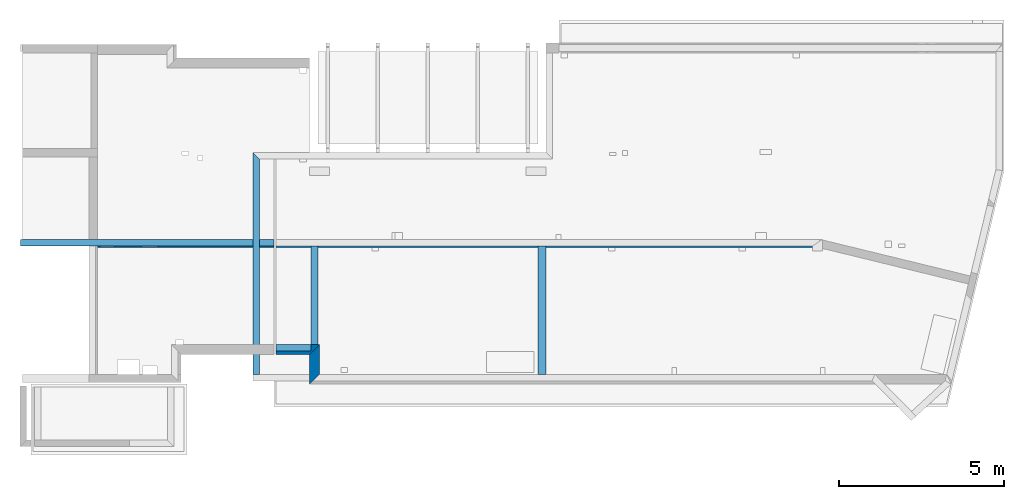
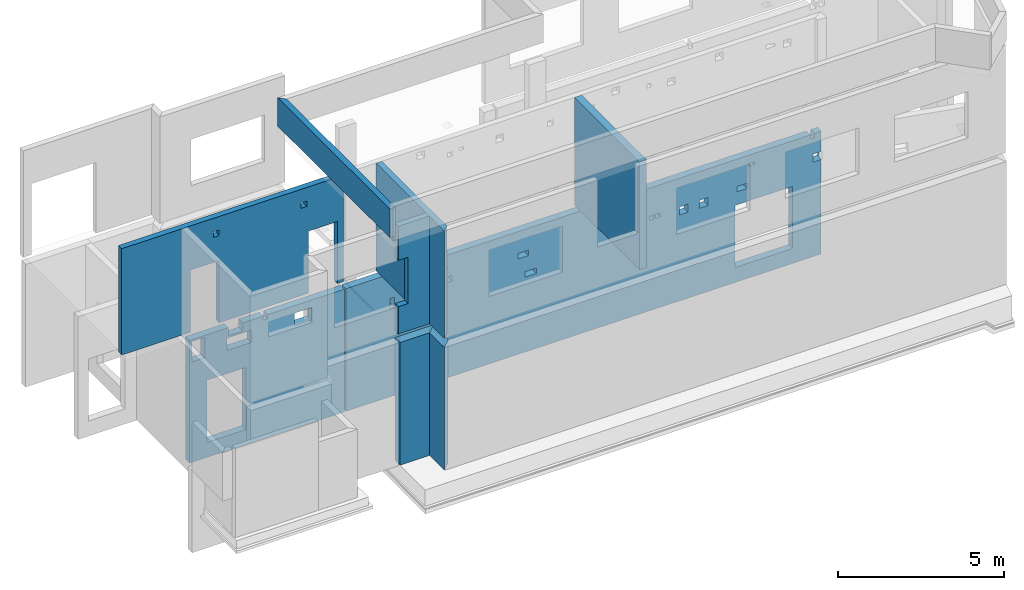
# One storey, part 2 of 7: 9 walls, 30 openings.
"""IFC2X3 building model written with IfcOpenShell, lengths in millimetres."""

from ifc_helpers import new_model, entity, si_unit, converted_unit, derived_unit, money_unit, direction, frame, frame_2d, origin_with_axes, place, context, subcontext, project, spatial, polyline, rectangle, outline, extrude, faceted_brep, material, layer, layer_set, layer_usage, type_object, element, save


model = new_model("IFC2X3")

# Units and contexts
model_context = context("Model", 3, precision=1e-05, world=origin_with_axes(), true_north=direction((0.0, 1.0)))
body_context = subcontext(model_context, "Body", "Model", "MODEL_VIEW", scale=1.0)
ifc_project = project(units=[si_unit("LENGTHUNIT", "METRE", prefix="MILLI"), si_unit("AREAUNIT", "SQUARE_METRE"), si_unit("VOLUMEUNIT", "CUBIC_METRE"), si_unit("ABSORBEDDOSEUNIT", "GRAY"), si_unit("AMOUNTOFSUBSTANCEUNIT", "MOLE"), si_unit("DOSEEQUIVALENTUNIT", "SIEVERT"), si_unit("ELECTRICCAPACITANCEUNIT", "FARAD"), si_unit("ELECTRICCHARGEUNIT", "COULOMB"), si_unit("ELECTRICCONDUCTANCEUNIT", "SIEMENS"), si_unit("ELECTRICCURRENTUNIT", "AMPERE"), si_unit("ELECTRICRESISTANCEUNIT", "OHM"), si_unit("ELECTRICVOLTAGEUNIT", "VOLT"), si_unit("ENERGYUNIT", "JOULE"), si_unit("FORCEUNIT", "NEWTON"), si_unit("FREQUENCYUNIT", "HERTZ"), si_unit("ILLUMINANCEUNIT", "LUX"), si_unit("INDUCTANCEUNIT", "HENRY"), si_unit("LUMINOUSFLUXUNIT", "LUMEN"), si_unit("LUMINOUSINTENSITYUNIT", "CANDELA"), si_unit("MAGNETICFLUXDENSITYUNIT", "TESLA"), si_unit("MAGNETICFLUXUNIT", "WEBER"), si_unit("MASSUNIT", "GRAM"), converted_unit("PLANEANGLEUNIT", "degree", entity("IfcReal", 0.0174532925199433), si_unit("PLANEANGLEUNIT", "RADIAN"), dimensions=[0, 0, 0, 0, 0, 0, 0]), si_unit("POWERUNIT", "WATT"), si_unit("PRESSUREUNIT", "PASCAL"), si_unit("RADIOACTIVITYUNIT", "BECQUEREL"), si_unit("SOLIDANGLEUNIT", "STERADIAN"), si_unit("THERMODYNAMICTEMPERATUREUNIT", "KELVIN"), si_unit("TIMEUNIT", "SECOND"), derived_unit("ACCELERATIONUNIT", [(si_unit("LENGTHUNIT", "METRE", prefix="MILLI"), 1), (si_unit("TIMEUNIT", "SECOND"), -2)]), derived_unit("ANGULARVELOCITYUNIT", [(converted_unit("PLANEANGLEUNIT", "degree", entity("IfcReal", 0.0174532925199433), si_unit("PLANEANGLEUNIT", "RADIAN"), dimensions=[0, 0, 0, 0, 0, 0, 0]), 1), (si_unit("TIMEUNIT", "SECOND"), -1)]), derived_unit("CURVATUREUNIT", [(converted_unit("PLANEANGLEUNIT", "degree", entity("IfcReal", 0.0174532925199433), si_unit("PLANEANGLEUNIT", "RADIAN"), dimensions=[0, 0, 0, 0, 0, 0, 0]), 1), (si_unit("LENGTHUNIT", "METRE", prefix="MILLI"), -1)]), derived_unit("DYNAMICVISCOSITYUNIT", [(si_unit("PRESSUREUNIT", "PASCAL"), 1), (si_unit("TIMEUNIT", "SECOND"), 1)]), derived_unit("HEATFLUXDENSITYUNIT", [(si_unit("POWERUNIT", "WATT"), 1), (si_unit("LENGTHUNIT", "METRE", prefix="MILLI"), -2)]), derived_unit("HEATINGVALUEUNIT", [(si_unit("ENERGYUNIT", "JOULE"), 1), (si_unit("MASSUNIT", "GRAM"), -1)]), derived_unit("INTEGERCOUNTRATEUNIT", [(si_unit("TIMEUNIT", "SECOND"), -1)]), derived_unit("IONCONCENTRATIONUNIT", [(si_unit("MASSUNIT", "GRAM"), 1), (si_unit("VOLUMEUNIT", "CUBIC_METRE"), -1)]), derived_unit("ISOTHERMALMOISTURECAPACITYUNIT", [(si_unit("VOLUMEUNIT", "CUBIC_METRE"), 1), (si_unit("MASSUNIT", "GRAM"), -1)]), derived_unit("KINEMATICVISCOSITYUNIT", [(si_unit("AREAUNIT", "SQUARE_METRE"), 1), (si_unit("TIMEUNIT", "SECOND"), -1)]), derived_unit("LINEARFORCEUNIT", [(si_unit("FORCEUNIT", "NEWTON"), 1), (si_unit("LENGTHUNIT", "METRE", prefix="MILLI"), -1)]), derived_unit("LINEARMOMENTUNIT", [(si_unit("FORCEUNIT", "NEWTON"), 1), (si_unit("LENGTHUNIT", "METRE", prefix="MILLI"), -1)]), derived_unit("LINEARSTIFFNESSUNIT", [(si_unit("FORCEUNIT", "NEWTON"), 1), (si_unit("LENGTHUNIT", "METRE", prefix="MILLI"), -1)]), derived_unit("LINEARVELOCITYUNIT", [(si_unit("LENGTHUNIT", "METRE", prefix="MILLI"), 1), (si_unit("TIMEUNIT", "SECOND"), -1)]), derived_unit("LUMINOUSINTENSITYDISTRIBUTIONUNIT", [(si_unit("LUMINOUSINTENSITYUNIT", "CANDELA"), 1), (si_unit("LUMINOUSFLUXUNIT", "LUMEN"), -1)]), derived_unit("MASSDENSITYUNIT", [(si_unit("MASSUNIT", "GRAM"), 1), (si_unit("VOLUMEUNIT", "CUBIC_METRE"), -1)]), derived_unit("MASSFLOWRATEUNIT", [(si_unit("MASSUNIT", "GRAM"), 1), (si_unit("TIMEUNIT", "SECOND"), -1)]), derived_unit("MASSPERLENGTHUNIT", [(si_unit("MASSUNIT", "GRAM"), 1), (si_unit("LENGTHUNIT", "METRE", prefix="MILLI"), -1)]), derived_unit("MODULUSOFELASTICITYUNIT", [(si_unit("FORCEUNIT", "NEWTON"), 1), (si_unit("AREAUNIT", "SQUARE_METRE"), -1)]), derived_unit("MODULUSOFLINEARSUBGRADEREACTIONUNIT", [(si_unit("FORCEUNIT", "NEWTON"), 1), (si_unit("LENGTHUNIT", "METRE", prefix="MILLI"), -2)]), derived_unit("MODULUSOFROTATIONALSUBGRADEREACTIONUNIT", [(si_unit("FORCEUNIT", "NEWTON"), 1), (si_unit("LENGTHUNIT", "METRE", prefix="MILLI"), 1)]), derived_unit("MODULUSOFSUBGRADEREACTIONUNIT", [(si_unit("FORCEUNIT", "NEWTON"), 1), (si_unit("VOLUMEUNIT", "CUBIC_METRE"), -1)]), derived_unit("MOISTUREDIFFUSIVITYUNIT", [(si_unit("VOLUMEUNIT", "CUBIC_METRE"), 1), (si_unit("TIMEUNIT", "SECOND"), -1)]), derived_unit("MOLECULARWEIGHTUNIT", [(si_unit("MASSUNIT", "GRAM"), 1), (si_unit("AMOUNTOFSUBSTANCEUNIT", "MOLE"), -1)]), derived_unit("PLANARFORCEUNIT", [(si_unit("FORCEUNIT", "NEWTON"), 1), (si_unit("LENGTHUNIT", "METRE", prefix="MILLI"), -2)]), derived_unit("ROTATIONALFREQUENCYUNIT", [(si_unit("TIMEUNIT", "SECOND"), -1)]), derived_unit("ROTATIONALMASSUNIT", [(si_unit("MASSUNIT", "GRAM"), 1), (si_unit("LENGTHUNIT", "METRE", prefix="MILLI"), 2)]), derived_unit("ROTATIONALSTIFFNESSUNIT", [(si_unit("FORCEUNIT", "NEWTON"), 1), (si_unit("LENGTHUNIT", "METRE", prefix="MILLI"), 1), (converted_unit("PLANEANGLEUNIT", "degree", entity("IfcReal", 0.0174532925199433), si_unit("PLANEANGLEUNIT", "RADIAN"), dimensions=[0, 0, 0, 0, 0, 0, 0]), -1)]), derived_unit("SECTIONAREAINTEGRALUNIT", [(si_unit("LENGTHUNIT", "METRE", prefix="MILLI"), 5)]), derived_unit("SECTIONMODULUSUNIT", [(si_unit("LENGTHUNIT", "METRE", prefix="MILLI"), 3)]), derived_unit("SHEARMODULUSUNIT", [(si_unit("FORCEUNIT", "NEWTON"), 1), (si_unit("AREAUNIT", "SQUARE_METRE"), -1)]), derived_unit("SOUNDPOWERUNIT", [(si_unit("ENERGYUNIT", "JOULE"), 1), (si_unit("TIMEUNIT", "SECOND"), -1)]), derived_unit("SPECIFICHEATCAPACITYUNIT", [(si_unit("FORCEUNIT", "NEWTON"), 1), (si_unit("MASSUNIT", "GRAM"), -1), (si_unit("THERMODYNAMICTEMPERATUREUNIT", "KELVIN"), -1)]), derived_unit("TEMPERATUREGRADIENTUNIT", [(si_unit("THERMODYNAMICTEMPERATUREUNIT", "KELVIN"), 1), (si_unit("LENGTHUNIT", "METRE", prefix="MILLI"), -1)]), derived_unit("THERMALADMITTANCEUNIT", [(si_unit("POWERUNIT", "WATT"), 1), (si_unit("AREAUNIT", "SQUARE_METRE"), -1), (si_unit("THERMODYNAMICTEMPERATUREUNIT", "KELVIN"), -1)]), derived_unit("THERMALCONDUCTANCEUNIT", [(si_unit("POWERUNIT", "WATT"), 1), (si_unit("LENGTHUNIT", "METRE", prefix="MILLI"), -1), (si_unit("THERMODYNAMICTEMPERATUREUNIT", "KELVIN"), -1)]), derived_unit("THERMALEXPANSIONCOEFFICIENTUNIT", [(si_unit("THERMODYNAMICTEMPERATUREUNIT", "KELVIN"), -1)]), derived_unit("THERMALRESISTANCEUNIT", [(si_unit("AREAUNIT", "SQUARE_METRE"), 1), (si_unit("POWERUNIT", "WATT"), -1)]), derived_unit("THERMALTRANSMITTANCEUNIT", [(si_unit("POWERUNIT", "WATT"), 1), (si_unit("AREAUNIT", "SQUARE_METRE"), -1), (si_unit("THERMODYNAMICTEMPERATUREUNIT", "KELVIN"), -1)]), derived_unit("TORQUEUNIT", [(si_unit("FORCEUNIT", "NEWTON"), 1), (si_unit("LENGTHUNIT", "METRE", prefix="MILLI"), 1)]), derived_unit("VAPORPERMEABILITYUNIT", [(si_unit("MASSUNIT", "GRAM"), 1), (si_unit("TIMEUNIT", "SECOND"), -1)]), derived_unit("VOLUMETRICFLOWRATEUNIT", [(si_unit("VOLUMEUNIT", "CUBIC_METRE"), 1), (si_unit("TIMEUNIT", "SECOND"), -1)]), derived_unit("WARPINGCONSTANTUNIT", [(si_unit("LENGTHUNIT", "METRE", prefix="MILLI"), 6)]), derived_unit("WARPINGMOMENTUNIT", [(si_unit("FORCEUNIT", "NEWTON"), 1), (si_unit("LENGTHUNIT", "METRE", prefix="MILLI"), 2)]), money_unit("USD")], contexts=[model_context])

# Site, building, storey
site_placement = place(None, origin_with_axes())
site = spatial("IfcSite", under=ifc_project, at=site_placement, CompositionType="ELEMENT")
building_placement = place(site_placement, origin_with_axes())
building = spatial("IfcBuilding", under=site, at=building_placement, Name="1", CompositionType="ELEMENT")
storey_placement = place(building_placement, frame((0.0, 0.0, -4900.0), z_axis=(0.0, 0.0, 1.0), x_axis=(1.0, 0.0, 0.0)))
storey = spatial("IfcBuildingStorey", under=building, at=storey_placement, Name="-2", CompositionType="ELEMENT", Elevation=-4900.0)

# Wall, openings
ifc_material = material()
ifc_layer_1 = layer(ifc_material, 250.0, ventilated=False)
ifc_layer_set_1 = layer_set([ifc_layer_1])
ifc_layer_usage_1 = layer_usage(ifc_layer_set_1, "AXIS2", "POSITIVE", 0.0)
wall_type = type_object("IfcWallType", PredefinedType="NOTDEFINED")
wall_1_placement = place(storey_placement, frame((2530.0, 3850.0, 0.0), z_axis=(0.0, 0.0, 1.0), x_axis=(1.0, 0.0, 0.0)))
wall_1 = element("IfcWallStandardCase", 1, at=wall_1_placement, inside=storey, type_object=wall_type, material=ifc_layer_usage_1, context=body_context, shape_type="SweptSolid", body=[
    extrude(rectangle(XDim=5370.0, YDim=250.0, at=frame_2d((2685.0, 125.0), x_axis=(1.0, 0.0))), origin_with_axes(), (0.0, 0.0, 1.0), 4500.0),
])
opening_1_placement = place(wall_1_placement, frame((600.0, 0.0, 550.0), z_axis=(0.0, 0.0, 1.0), x_axis=(1.0, 0.0, 0.0)))
element("IfcOpeningElement", 2, at=opening_1_placement, cuts=wall_1, ObjectType="Opening", context=body_context, shape_type="SweptSolid", body=[
    extrude(rectangle(XDim=2280.0, YDim=1350.0, at=frame_2d((-675.0, 1140.0), x_axis=(0.0, -1.0))), frame((0.0, 0.0, 0.0), z_axis=(0.0, 1.0, 0.0), x_axis=(-1.0, 0.0, 0.0)), (0.0, 0.0, 1.0), 250.0),
])
opening_2_placement = place(wall_1_placement, frame((75.0, 0.0, 3680.0), z_axis=(0.0, 0.0, 1.0), x_axis=(1.0, 0.0, 0.0)))
element("IfcOpeningElement", 3, at=opening_2_placement, cuts=wall_1, ObjectType="Opening", context=body_context, shape_type="SweptSolid", body=[
    extrude(rectangle(XDim=750.0, YDim=450.0, at=frame_2d((-225.0, 375.0), x_axis=(0.0, -1.0))), frame((0.0, 0.0, 0.0), z_axis=(0.0, 1.0, 0.0), x_axis=(-1.0, 0.0, 0.0)), (0.0, 0.0, 1.0), 250.0),
])
opening_3_placement = place(wall_1_placement, frame((1290.0, 0.0, 3680.0), z_axis=(0.0, 0.0, 1.0), x_axis=(1.0, 0.0, 0.0)))
element("IfcOpeningElement", 4, at=opening_3_placement, cuts=wall_1, ObjectType="Opening", context=body_context, shape_type="SweptSolid", body=[
    extrude(rectangle(XDim=450.0, YDim=850.0, at=frame_2d((-425.0, 225.0), x_axis=(0.0, -1.0))), frame((0.0, 0.0, 0.0), z_axis=(0.0, 1.0, 0.0), x_axis=(-1.0, 0.0, 0.0)), (0.0, 0.0, 1.0), 250.0),
])
opening_4_placement = place(wall_1_placement, frame((1340.0, 0.0, 4200.0), z_axis=(0.0, 0.0, 1.0), x_axis=(1.0, 0.0, 0.0)))
element("IfcOpeningElement", 5, at=opening_4_placement, cuts=wall_1, ObjectType="Opening", context=body_context, shape_type="SweptSolid", body=[
    extrude(rectangle(XDim=300.0, YDim=500.0, at=frame_2d((-250.0, 150.0), x_axis=(0.0, -1.0))), frame((0.0, 0.0, 0.0), z_axis=(0.0, 1.0, 0.0), x_axis=(-1.0, 0.0, 0.0)), (0.0, 0.0, 1.0), 250.0),
])
opening_5_placement = place(wall_1_placement, frame((2550.0, 0.0, 4350.0), z_axis=(0.0, 0.0, 1.0), x_axis=(1.0, 0.0, 0.0)))
element("IfcOpeningElement", 6, at=opening_5_placement, cuts=wall_1, ObjectType="Opening", context=body_context, shape_type="SweptSolid", body=[
    extrude(rectangle(XDim=150.0, YDim=150.0, at=frame_2d((-75.0, 75.0), x_axis=(0.0, -1.0))), frame((0.0, 0.0, 0.0), z_axis=(0.0, 1.0, 0.0), x_axis=(-1.0, 0.0, 0.0)), (0.0, 0.0, 1.0), 250.0),
])
opening_6_placement = place(wall_1_placement, frame((3630.0, 0.0, 3780.0), z_axis=(0.0, 0.0, 1.0), x_axis=(1.0, 0.0, 0.0)))
element("IfcOpeningElement", 7, at=opening_6_placement, cuts=wall_1, ObjectType="Opening", context=body_context, shape_type="SweptSolid", body=[
    extrude(rectangle(XDim=450.0, YDim=600.0, at=frame_2d((-300.0, 225.0), x_axis=(0.0, -1.0))), frame((0.0, 0.0, 0.0), z_axis=(0.0, 1.0, 0.0), x_axis=(-1.0, 0.0, 0.0)), (0.0, 0.0, 1.0), 250.0),
])

wall_2_placement = place(storey_placement, frame((7950.0, 3850.0, 0.0), z_axis=(0.0, 0.0, 1.0), x_axis=(1.0, 0.0, 0.0)))
wall_2 = element("IfcWallStandardCase", 8, at=wall_2_placement, inside=storey, type_object=wall_type, material=ifc_layer_usage_1, context=body_context, shape_type="SweptSolid", body=[
    extrude(outline(polyline([(16515.0, 250.0), (0.0, 250.0), (0.0, 0.0), (16484.99, 0.0), (16515.0, 250.0)])), origin_with_axes(), (0.0, 0.0, 1.0), 4500.0),
])
opening_7_placement = place(wall_2_placement, frame((13495.0, 0.0, 550.0), z_axis=(0.0, 0.0, 1.0), x_axis=(1.0, 0.0, 0.0)))
element("IfcOpeningElement", 9, at=opening_7_placement, cuts=wall_2, ObjectType="Opening", context=body_context, shape_type="SweptSolid", body=[
    extrude(rectangle(XDim=2280.0, YDim=2000.0, at=frame_2d((-1000.0, 1140.0), x_axis=(0.0, -1.0))), frame((0.0, 0.0, 0.0), z_axis=(0.0, 1.0, 0.0), x_axis=(-1.0, 0.0, 0.0)), (0.0, 0.0, 1.0), 250.0),
])
opening_8_placement = place(wall_2_placement, frame((1525.0, 0.0, 3240.0), z_axis=(0.0, 0.0, 1.0), x_axis=(1.0, 0.0, 0.0)))
element("IfcOpeningElement", 10, at=opening_8_placement, cuts=wall_2, ObjectType="Opening", context=body_context, shape_type="SweptSolid", body=[
    extrude(rectangle(XDim=360.0, YDim=150.0, at=frame_2d((-75.0, 180.0), x_axis=(0.0, -1.0))), frame((0.0, 0.0, 0.0), z_axis=(0.0, 1.0, 0.0), x_axis=(-1.0, 0.0, 0.0)), (0.0, 0.0, 1.0), 250.0),
])
opening_9_placement = place(wall_2_placement, frame((3025.0, 0.0, 3500.0), z_axis=(0.0, 0.0, 1.0), x_axis=(1.0, 0.0, 0.0)))
element("IfcOpeningElement", 11, at=opening_9_placement, cuts=wall_2, ObjectType="Opening", context=body_context, shape_type="SweptSolid", body=[
    extrude(rectangle(XDim=200.0, YDim=200.0, at=frame_2d((-100.0, 100.0), x_axis=(0.0, -1.0))), frame((0.0, 0.0, 0.0), z_axis=(0.0, 1.0, 0.0), x_axis=(-1.0, 0.0, 0.0)), (0.0, 0.0, 1.0), 250.0),
])
opening_10_placement = place(wall_2_placement, frame((3475.0, 0.0, 3500.0), z_axis=(0.0, 0.0, 1.0), x_axis=(1.0, 0.0, 0.0)))
element("IfcOpeningElement", 12, at=opening_10_placement, cuts=wall_2, ObjectType="Opening", context=body_context, shape_type="SweptSolid", body=[
    extrude(rectangle(XDim=200.0, YDim=200.0, at=frame_2d((-100.0, 100.0), x_axis=(0.0, -1.0))), frame((0.0, 0.0, 0.0), z_axis=(0.0, 1.0, 0.0), x_axis=(-1.0, 0.0, 0.0)), (0.0, 0.0, 1.0), 250.0),
])
opening_11_placement = place(wall_2_placement, frame((5975.0, 0.0, 3500.0), z_axis=(0.0, 0.0, 1.0), x_axis=(1.0, 0.0, 0.0)))
element("IfcOpeningElement", 13, at=opening_11_placement, cuts=wall_2, ObjectType="Opening", context=body_context, shape_type="SweptSolid", body=[
    extrude(rectangle(XDim=200.0, YDim=350.0, at=frame_2d((-175.0, 100.0), x_axis=(0.0, -1.0))), frame((0.0, 0.0, 0.0), z_axis=(0.0, 1.0, 0.0), x_axis=(-1.0, 0.0, 0.0)), (0.0, 0.0, 1.0), 250.0),
])
opening_12_placement = place(wall_2_placement, frame((3315.0, 0.0, 4000.0), z_axis=(0.0, 0.0, 1.0), x_axis=(1.0, 0.0, 0.0)))
element("IfcOpeningElement", 14, at=opening_12_placement, cuts=wall_2, ObjectType="Opening", context=body_context, shape_type="SweptSolid", body=[
    extrude(rectangle(XDim=100.0, YDim=200.0, at=frame_2d((-100.0, 50.0), x_axis=(0.0, -1.0))), frame((0.0, 0.0, 0.0), z_axis=(0.0, 1.0, 0.0), x_axis=(-1.0, 0.0, 0.0)), (0.0, 0.0, 1.0), 250.0),
])
opening_13_placement = place(wall_2_placement, frame((6205.0, 0.0, 2750.0), z_axis=(0.0, 0.0, 1.0), x_axis=(1.0, 0.0, 0.0)))
element("IfcOpeningElement", 15, at=opening_13_placement, cuts=wall_2, ObjectType="Opening", context=body_context, shape_type="SweptSolid", body=[
    extrude(rectangle(XDim=200.0, YDim=400.0, at=frame_2d((-200.0, 100.0), x_axis=(0.0, -1.0))), frame((0.0, 0.0, 0.0), z_axis=(0.0, 1.0, 0.0), x_axis=(-1.0, 0.0, 0.0)), (0.0, 0.0, 1.0), 250.0),
])
opening_14_placement = place(wall_2_placement, frame((9635.0, 0.0, 3300.0), z_axis=(0.0, 0.0, 1.0), x_axis=(1.0, 0.0, 0.0)))
element("IfcOpeningElement", 16, at=opening_14_placement, cuts=wall_2, ObjectType="Opening", context=body_context, shape_type="SweptSolid", body=[
    extrude(rectangle(XDim=200.0, YDim=200.0, at=frame_2d((-100.0, 100.0), x_axis=(0.0, -1.0))), frame((0.0, 0.0, 0.0), z_axis=(0.0, 1.0, 0.0), x_axis=(-1.0, 0.0, 0.0)), (0.0, 0.0, 1.0), 250.0),
])
opening_15_placement = place(wall_2_placement, frame((9985.0, 0.0, 3300.0), z_axis=(0.0, 0.0, 1.0), x_axis=(1.0, 0.0, 0.0)))
element("IfcOpeningElement", 17, at=opening_15_placement, cuts=wall_2, ObjectType="Opening", context=body_context, shape_type="SweptSolid", body=[
    extrude(rectangle(XDim=200.0, YDim=200.0, at=frame_2d((-100.0, 100.0), x_axis=(0.0, -1.0))), frame((0.0, 0.0, 0.0), z_axis=(0.0, 1.0, 0.0), x_axis=(-1.0, 0.0, 0.0)), (0.0, 0.0, 1.0), 250.0),
])
opening_16_placement = place(wall_2_placement, frame((10535.0, 0.0, 3325.0), z_axis=(0.0, 0.0, 1.0), x_axis=(1.0, 0.0, 0.0)))
element("IfcOpeningElement", 18, at=opening_16_placement, cuts=wall_2, ObjectType="Opening", context=body_context, shape_type="SweptSolid", body=[
    extrude(rectangle(XDim=150.0, YDim=150.0, at=frame_2d((-75.0, 75.0), x_axis=(0.0, -1.0))), frame((0.0, 0.0, 0.0), z_axis=(0.0, 1.0, 0.0), x_axis=(-1.0, 0.0, 0.0)), (0.0, 0.0, 1.0), 250.0),
])
opening_17_placement = place(wall_2_placement, frame((10745.0, 0.0, 3325.0), z_axis=(0.0, 0.0, 1.0), x_axis=(1.0, 0.0, 0.0)))
element("IfcOpeningElement", 19, at=opening_17_placement, cuts=wall_2, ObjectType="Opening", context=body_context, shape_type="SweptSolid", body=[
    extrude(rectangle(XDim=150.0, YDim=150.0, at=frame_2d((-75.0, 75.0), x_axis=(0.0, -1.0))), frame((0.0, 0.0, 0.0), z_axis=(0.0, 1.0, 0.0), x_axis=(-1.0, 0.0, 0.0)), (0.0, 0.0, 1.0), 250.0),
])
opening_18_placement = place(wall_2_placement, frame((11565.0, 0.0, 3150.0), z_axis=(0.0, 0.0, 1.0), x_axis=(1.0, 0.0, 0.0)))
element("IfcOpeningElement", 20, at=opening_18_placement, cuts=wall_2, ObjectType="Opening", context=body_context, shape_type="SweptSolid", body=[
    extrude(rectangle(XDim=300.0, YDim=300.0, at=frame_2d((-150.0, 150.0), x_axis=(0.0, -1.0))), frame((0.0, 0.0, 0.0), z_axis=(0.0, 1.0, 0.0), x_axis=(-1.0, 0.0, 0.0)), (0.0, 0.0, 1.0), 250.0),
])
opening_19_placement = place(wall_2_placement, frame((12265.0, 0.0, 3150.0), z_axis=(0.0, 0.0, 1.0), x_axis=(1.0, 0.0, 0.0)))
element("IfcOpeningElement", 21, at=opening_19_placement, cuts=wall_2, ObjectType="Opening", context=body_context, shape_type="SweptSolid", body=[
    extrude(rectangle(XDim=300.0, YDim=300.0, at=frame_2d((-150.0, 150.0), x_axis=(0.0, -1.0))), frame((0.0, 0.0, 0.0), z_axis=(0.0, 1.0, 0.0), x_axis=(-1.0, 0.0, 0.0)), (0.0, 0.0, 1.0), 250.0),
])
opening_20_placement = place(wall_2_placement, frame((13565.0, 0.0, 3300.0), z_axis=(0.0, 0.0, 1.0), x_axis=(1.0, 0.0, 0.0)))
element("IfcOpeningElement", 22, at=opening_20_placement, cuts=wall_2, ObjectType="Opening", context=body_context, shape_type="SweptSolid", body=[
    extrude(rectangle(XDim=200.0, YDim=350.0, at=frame_2d((-175.0, 100.0), x_axis=(0.0, -1.0))), frame((0.0, 0.0, 0.0), z_axis=(0.0, 1.0, 0.0), x_axis=(-1.0, 0.0, 0.0)), (0.0, 0.0, 1.0), 250.0),
])
opening_21_placement = place(wall_2_placement, frame((16205.0, 0.0, 3465.0), z_axis=(0.0, 0.0, 1.0), x_axis=(1.0, 0.0, 0.0)))
element("IfcOpeningElement", 23, at=opening_21_placement, cuts=wall_2, ObjectType="Opening", context=body_context, shape_type="SweptSolid", body=[
    extrude(rectangle(XDim=300.0, YDim=300.0, at=frame_2d((-150.0, 150.0), x_axis=(0.0, -1.0))), frame((0.0, 0.0, 0.0), z_axis=(0.0, 1.0, 0.0), x_axis=(-1.0, 0.0, 0.0)), (0.0, 0.0, 1.0), 250.0),
])
opening_22_placement = place(wall_2_placement, frame((9549.96, 0.0, 2950.0), z_axis=(0.0, 0.0, 1.0), x_axis=(1.0, 0.0, 0.0)))
element("IfcOpeningElement", 24, at=opening_22_placement, cuts=wall_2, ObjectType="Opening", context=body_context, shape_type="SweptSolid", body=[
    extrude(rectangle(XDim=200.0, YDim=400.0, at=frame_2d((-200.0, 100.0), x_axis=(0.0, -1.0))), frame((0.0, 0.0, 0.0), z_axis=(0.0, 1.0, 0.0), x_axis=(-1.0, 0.0, 0.0)), (0.0, 0.0, 1.0), 250.0),
])
opening_23_placement = place(wall_2_placement, frame((10079.96, 0.0, 4100.0), z_axis=(0.0, 0.0, 1.0), x_axis=(1.0, 0.0, 0.0)))
element("IfcOpeningElement", 25, at=opening_23_placement, cuts=wall_2, ObjectType="Opening", context=body_context, shape_type="SweptSolid", body=[
    extrude(rectangle(XDim=100.0, YDim=200.0, at=frame_2d((-100.0, 50.0), x_axis=(0.0, -1.0))), frame((0.0, 0.0, 0.0), z_axis=(0.0, 1.0, 0.0), x_axis=(-1.0, 0.0, 0.0)), (0.0, 0.0, 1.0), 250.0),
])
opening_24_placement = place(wall_2_placement, frame((13965.0, 0.0, 4100.0), z_axis=(0.0, 0.0, 1.0), x_axis=(1.0, 0.0, 0.0)))
element("IfcOpeningElement", 26, at=opening_24_placement, cuts=wall_2, ObjectType="Opening", context=body_context, shape_type="SweptSolid", body=[
    extrude(rectangle(XDim=100.0, YDim=200.0, at=frame_2d((-100.0, 50.0), x_axis=(0.0, -1.0))), frame((0.0, 0.0, 0.0), z_axis=(0.0, 1.0, 0.0), x_axis=(-1.0, 0.0, 0.0)), (0.0, 0.0, 1.0), 250.0),
])
opening_25_placement = place(wall_2_placement, frame((16105.0, 0.0, 4350.0), z_axis=(0.0, 0.0, 1.0), x_axis=(1.0, 0.0, 0.0)))
element("IfcOpeningElement", 27, at=opening_25_placement, cuts=wall_2, ObjectType="Opening", context=body_context, shape_type="SweptSolid", body=[
    extrude(rectangle(XDim=150.0, YDim=150.0, at=frame_2d((-75.0, 75.0), x_axis=(0.0, -1.0))), frame((0.0, 0.0, 0.0), z_axis=(0.0, 1.0, 0.0), x_axis=(-1.0, 0.0, 0.0)), (0.0, 0.0, 1.0), 250.0),
])

# Walls
ifc_layer_2 = layer(ifc_material, 300.0, ventilated=False)
ifc_layer_set_2 = layer_set([ifc_layer_2])
ifc_layer_usage_2 = layer_usage(ifc_layer_set_2, "AXIS2", "POSITIVE", 0.0)
wall_3_placement = place(storey_placement, frame((7950.0, 600.0, 0.0), z_axis=(0.0, 0.0, 1.0), x_axis=(1.0, 0.0, 0.0)))
element("IfcWallStandardCase", 28, at=wall_3_placement, inside=storey, type_object=wall_type, material=ifc_layer_usage_2, context=body_context, shape_type="SweptSolid", body=[
    extrude(outline(polyline([(1325.0, 300.0), (0.0, 300.0), (0.0, 0.0), (1025.0, 0.0), (1325.0, 300.0)])), origin_with_axes(), (0.0, 0.0, 1.0), 4500.0),
])
wall_4_placement = place(storey_placement, frame((8975.0, 600.0, 0.0), z_axis=(0.0, 0.0, 1.0), x_axis=(0.0, -1.0, 0.0)))
element("IfcWallStandardCase", 29, at=wall_4_placement, inside=storey, type_object=wall_type, material=ifc_layer_usage_2, context=body_context, shape_type="SweptSolid", body=[
    extrude(outline(polyline([(600.0, 300.0), (-300.0, 300.0), (0.0, 0.0), (900.0, 0.0), (600.0, 300.0)])), origin_with_axes(), (0.0, 0.0, 1.0), 4500.0),
])
wall_5_placement = place(storey_placement, frame((15905.0, 0.0, 4750.0), z_axis=(0.0, 0.0, 1.0), x_axis=(0.0, 1.0, 0.0)))
element("IfcWallStandardCase", 30, at=wall_5_placement, inside=storey, type_object=wall_type, material=ifc_layer_usage_1, context=body_context, shape_type="SweptSolid", body=[
    extrude(rectangle(XDim=3900.0, YDim=250.0, at=frame_2d((1950.0, -125.0), x_axis=(1.0, 0.0))), origin_with_axes(), (0.0, 0.0, 1.0), 3950.0),
])
ifc_layer_3 = layer(ifc_material, 200.0, ventilated=False)
ifc_layer_set_3 = layer_set([ifc_layer_3])
ifc_layer_usage_3 = layer_usage(ifc_layer_set_3, "AXIS2", "POSITIVE", 0.0)
wall_6_placement = place(storey_placement, frame((9025.0, -200.0, 4750.0), z_axis=(0.0, 0.0, 1.0), x_axis=(0.0, 1.0, 0.0)))
element("IfcWallStandardCase", 31, at=wall_6_placement, inside=storey, type_object=wall_type, material=ifc_layer_usage_3, context=body_context, shape_type="SweptSolid", body=[
    extrude(outline(polyline([(0.0, 0.0), (200.0, -200.0), (4100.0, -200.0), (4100.0, 0.0), (0.0, 0.0)])), origin_with_axes(), (0.0, 0.0, 1.0), 3950.0),
])

# Wall, opening
wall_7_placement = place(storey_placement, frame((7950.0, 700.0, 4750.0), z_axis=(0.0, 0.0, 1.0), x_axis=(1.0, 0.0, 0.0)))
wall_7 = element("IfcWallStandardCase", 32, at=wall_7_placement, inside=storey, type_object=wall_type, material=ifc_layer_usage_3, context=body_context, shape_type="SweptSolid", body=[
    extrude(rectangle(XDim=1075.0, YDim=200.0, at=frame_2d((537.5, 100.0), x_axis=(-1.0, 0.0))), origin_with_axes(), (0.0, 0.0, 1.0), 3950.0),
])
opening_26_placement = place(wall_7_placement, frame((0.0, 0.0, 1000.0), z_axis=(0.0, 0.0, 1.0), x_axis=(1.0, 0.0, 0.0)))
element("IfcOpeningElement", 33, at=opening_26_placement, cuts=wall_7, ObjectType="Opening", context=body_context, shape_type="Brep", body=[
    faceted_brep([(325.0, 200.0, 0.0), (0.0, 200.0, 0.0), (0.0, 200.0, 1700.0), (325.0, 200.0, 1700.0), (0.0, 0.0, 0.0), (0.0, 0.0, 1700.0), (325.0, 0.0, 0.0), (325.0, 0.0, 1700.0)], [[[0, 1, 2, 3]], [[1, 4, 5, 2]], [[4, 6, 7, 5]], [[1, 0, 6, 4]], [[3, 7, 6, 0]], [[5, 7, 3, 2]]]),
])

# Wall, openings
wall_8_placement = place(storey_placement, frame((200.0, 3900.0, 4750.0), z_axis=(0.0, 0.0, 1.0), x_axis=(1.0, 0.0, 0.0)))
wall_8 = element("IfcWallStandardCase", 34, at=wall_8_placement, inside=storey, type_object=wall_type, material=ifc_layer_usage_3, context=body_context, shape_type="SweptSolid", body=[
    extrude(rectangle(XDim=7700.0, YDim=200.0, at=frame_2d((3850.0, 100.0), x_axis=(1.0, 0.0))), origin_with_axes(), (0.0, 0.0, 1.0), 3900.0),
])
opening_27_placement = place(wall_8_placement, frame((2380.0, 0.0, 0.0), z_axis=(0.0, 0.0, 1.0), x_axis=(1.0, 0.0, 0.0)))
element("IfcOpeningElement", 35, at=opening_27_placement, cuts=wall_8, ObjectType="Opening", context=body_context, shape_type="SweptSolid", body=[
    extrude(rectangle(XDim=2280.0, YDim=1000.0, at=frame_2d((-500.0, 1140.0), x_axis=(0.0, -1.0))), frame((0.0, 0.0, 0.0), z_axis=(0.0, 1.0, 0.0), x_axis=(-1.0, 0.0, 0.0)), (0.0, 0.0, 1.0), 200.0),
])
opening_28_placement = place(wall_8_placement, frame((6485.0, 0.0, 0.0), z_axis=(0.0, 0.0, 1.0), x_axis=(1.0, 0.0, 0.0)))
element("IfcOpeningElement", 36, at=opening_28_placement, cuts=wall_8, ObjectType="Opening", context=body_context, shape_type="SweptSolid", body=[
    extrude(rectangle(XDim=2280.0, YDim=1000.0, at=frame_2d((-500.0, 1140.0), x_axis=(0.0, -1.0))), frame((0.0, 0.0, 0.0), z_axis=(0.0, 1.0, 0.0), x_axis=(-1.0, 0.0, 0.0)), (0.0, 0.0, 1.0), 200.0),
])
opening_29_placement = place(wall_8_placement, frame((3180.0, 0.0, 3200.0), z_axis=(0.0, 0.0, 1.0), x_axis=(1.0, 0.0, 0.0)))
element("IfcOpeningElement", 37, at=opening_29_placement, cuts=wall_8, ObjectType="Opening", context=body_context, shape_type="SweptSolid", body=[
    extrude(rectangle(XDim=200.0, YDim=200.0, at=frame_2d((-100.0, 100.0), x_axis=(0.0, -1.0))), frame((0.0, 0.0, 0.0), z_axis=(0.0, 1.0, 0.0), x_axis=(-1.0, 0.0, 0.0)), (0.0, 0.0, 1.0), 200.0),
])
opening_30_placement = place(wall_8_placement, frame((6225.0, 0.0, 3200.0), z_axis=(0.0, 0.0, 1.0), x_axis=(1.0, 0.0, 0.0)))
element("IfcOpeningElement", 38, at=opening_30_placement, cuts=wall_8, ObjectType="Opening", context=body_context, shape_type="SweptSolid", body=[
    extrude(rectangle(XDim=200.0, YDim=200.0, at=frame_2d((-100.0, 100.0), x_axis=(0.0, -1.0))), frame((0.0, 0.0, 0.0), z_axis=(0.0, 1.0, 0.0), x_axis=(-1.0, 0.0, 0.0)), (0.0, 0.0, 1.0), 200.0),
])

# Wall
wall_9_placement = place(storey_placement, frame((7250.0, 0.0, 8950.0), z_axis=(0.0, 0.0, 1.0), x_axis=(0.0, 1.0, 0.0)))
element("IfcWallStandardCase", 39, at=wall_9_placement, inside=storey, type_object=wall_type, material=ifc_layer_usage_3, context=body_context, shape_type="SweptSolid", body=[
    extrude(outline(polyline([(6740.0, 0.0), (0.0, 0.0), (0.0, -200.0), (6540.0, -200.0), (6740.0, 0.0)])), origin_with_axes(), (0.0, 0.0, 1.0), 1050.0),
])

save(model, "model.ifc")
